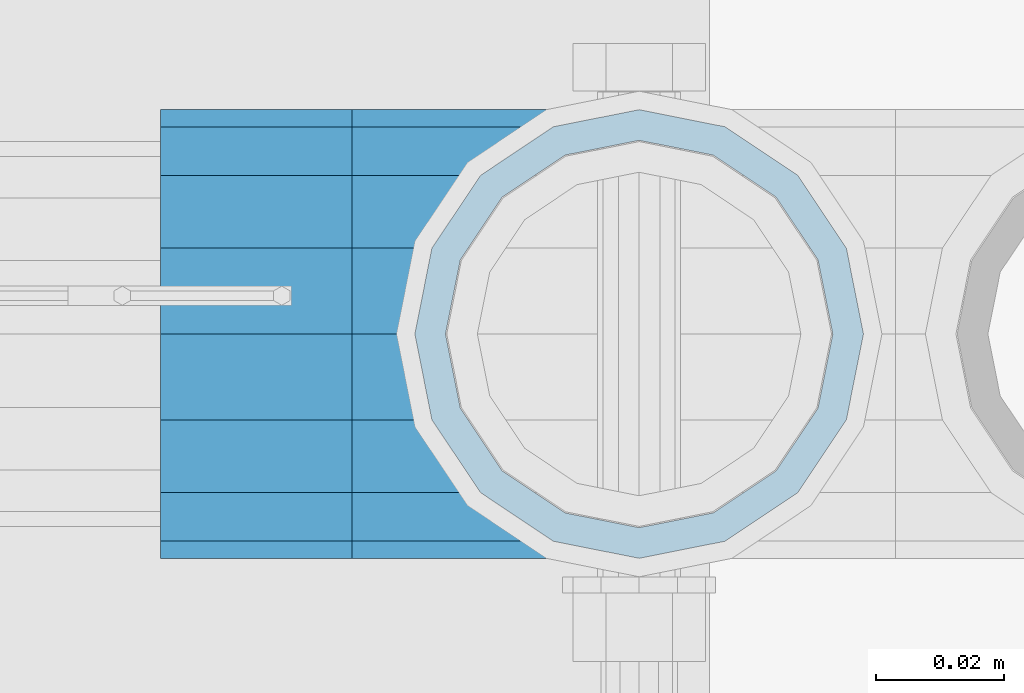
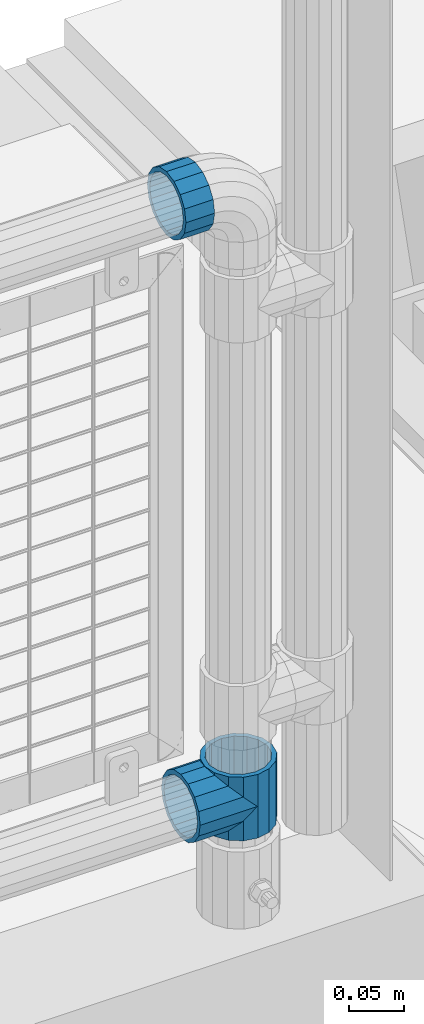
# One storey, part 169 of 242: 3 beams.
"""IFC2X3 building model written with IfcOpenShell, lengths in millimetres."""

from ifc_helpers import new_model, si_unit, frame, origin_with_axes, place, context, subcontext, project, spatial, faceted_brep, material, type_object, element, save


model = new_model("IFC2X3")

# Units and contexts
model_context = context("Model", 3, precision=1e-05, world=origin_with_axes())
body_context = subcontext(model_context, "Body", "Model", "MODEL_VIEW")
ifc_project = project(units=[si_unit("LENGTHUNIT", "METRE", prefix="MILLI"), si_unit("AREAUNIT", "SQUARE_METRE"), si_unit("VOLUMEUNIT", "CUBIC_METRE"), si_unit("MASSUNIT", "GRAM", prefix="KILO"), si_unit("TIMEUNIT", "SECOND"), si_unit("PLANEANGLEUNIT", "RADIAN"), si_unit("SOLIDANGLEUNIT", "STERADIAN"), si_unit("THERMODYNAMICTEMPERATUREUNIT", "DEGREE_CELSIUS"), si_unit("LUMINOUSINTENSITYUNIT", "LUMEN")], contexts=[model_context])

# Site, building, storey
site_placement = place(None, origin_with_axes())
site = spatial("IfcSite", under=ifc_project, at=site_placement, CompositionType="ELEMENT")
building_placement = place(site_placement, origin_with_axes())
building = spatial("IfcBuilding", under=site, at=building_placement, Name="Standard", CompositionType="ELEMENT")
storey_placement = place(building_placement, origin_with_axes())
storey = spatial("IfcBuildingStorey", under=building, at=storey_placement, Name="Undefined", CompositionType="ELEMENT", Elevation=0.0)

# Beams
ifc_material = material(Name="Misc_Undefined")
beam_type = type_object("IfcBeamType", PredefinedType="NOTDEFINED")
beam_1_placement = place(storey_placement, frame((-22656.0, -19335.5, 298.670000000001), z_axis=(0.0, 1.0, 0.0), x_axis=(-1.0, 0.0, 0.0)))
element("IfcBeam", 1, at=beam_1_placement, inside=storey, type_object=beam_type, material=ifc_material, context=body_context, shape_type="Brep", body=[
    faceted_brep([(0.0, 0.0, -35.1500000000015), (13.4513226476338, -13.4513226476329, -32.4743655677703), (13.4513226476338, 13.4513226476329, -32.4743655677703), (32.4743655677739, -26.8123795176754, 13.4513226476338), (32.4743655677739, -32.4743655677717, 13.4513226476338), (24.8548033587067, -24.8548033587072, 24.8548033587067), (24.8548033587067, -16.3810424080019, 24.8548033587067), (27.1226768591077, -21.4606908090117, 21.46069080901), (35.1500000000015, -30.35, 0.0), (35.1500000000015, -35.15, 0.0), (32.8397438117172, -28.0397438117175, 11.614442172282), (32.8397438117099, -28.0397438117175, -11.614442172282), (32.4743655677739, -26.8123795176754, -13.4513226476338), (32.4743655677739, -32.4743655677717, -13.4513226476338), (27.122676859115, -21.4606908090117, -21.46069080901), (24.8548033587067, -16.3810424080019, -24.8548033587067), (24.8548033587067, -24.8548033587072, -24.8548033587067), (20.0882031229849, -11.6144421722805, -28.0397438117179), (16.6306603983758, 0.0, -30.3499999999985), (20.0882031229849, 11.6144421722805, -28.0397438117179), (24.8548033587067, 16.3810424079986, -24.8548033587067), (24.8548033587067, 24.8548033587072, -24.8548033587067), (27.122676859115, 21.4606908090117, -21.46069080901), (32.4743655677739, 26.8123795176776, -13.4513226476338), (32.4743655677739, 32.4743655677717, -13.4513226476338), (32.8397438117099, 28.0397438117175, -11.614442172282), (35.1500000000015, 30.35, 0.0), (35.1500000000015, 35.1499999999996, 0.0), (32.8397438117172, 28.0397438117175, 11.614442172282), (32.4743655677739, 26.8123795176754, 13.4513226476338), (32.4743655677739, 32.4743655677717, 13.4513226476338), (27.1226768591077, 21.4606908090117, 21.46069080901), (24.8548033587067, 16.3810424080019, 24.8548033587067), (24.8548033587067, 24.8548033587072, 24.8548033587067), (13.4513226476338, 13.4513226476329, 32.4743655677703), (13.4513226476338, -13.4513226476329, 32.4743655677703), (0.0, 0.0, 35.1500000000015), (20.0882031229849, 11.6144421722805, 28.0397438117179), (16.6306603983685, 0.0, 30.3499999999985), (20.0882031229849, -11.6144421722805, 28.0397438117179), (60.1500000000015, -35.15, 0.0), (60.1500000000015, -32.4743655677717, 13.4513226476338), (60.1500000000015, -24.8548033587072, 24.8548033587067), (60.1500000000015, -13.4513226476329, 32.4743655677703), (60.1500000000015, 0.0, 35.1500000000015), (60.1500000000015, -24.8548033587072, -24.8548033587067), (60.1500000000015, -32.4743655677717, -13.4513226476338), (60.1500000000015, -13.4513226476329, -32.4743655677703), (60.1500000000015, 0.0, -35.1500000000015), (60.1500000000015, 13.4513226476329, -32.4743655677703), (60.1500000000015, 24.8548033587072, -24.8548033587067), (60.1500000000015, 32.4743655677717, -13.4513226476338), (60.1500000000015, 35.15, 0.0), (60.1500000000015, 32.4743655677717, 13.4513226476338), (60.1500000000015, 24.8548033587072, 24.8548033587067), (60.1500000000015, 13.4513226476329, 32.4743655677703), (60.1500000000015, -21.4606908090117, 21.46069080901), (60.1500000000015, -11.6144421722805, 28.0397438117179), (60.1500000000015, 0.0, 30.3499999999985), (60.1500000000015, 11.6144421722805, 28.0397438117179), (60.1500000000015, 21.4606908090117, 21.46069080901), (60.1500000000015, 28.0397438117175, 11.614442172282), (60.1500000000015, 30.35, 0.0), (60.1500000000015, 28.0397438117175, -11.614442172282), (60.1500000000015, 21.4606908090117, -21.46069080901), (60.1500000000015, 11.6144421722805, -28.0397438117179), (60.1500000000015, 0.0, -30.3499999999985), (60.1500000000015, -11.6144421722805, -28.0397438117179), (60.1500000000015, -21.4606908090117, -21.46069080901), (60.1500000000015, -28.0397438117175, -11.614442172282), (60.1500000000015, -30.35, 0.0), (60.1500000000015, -28.0397438117175, 11.614442172282)], [[[0, 1, 2]], [[3, 4, 5, 6, 7]], [[8, 9, 4, 3, 10]], [[11, 12, 13, 9, 8]], [[14, 15, 16, 13, 12]], [[2, 1, 16, 15, 17, 18, 19, 20, 21]], [[21, 20, 22, 23, 24]], [[24, 23, 25, 26, 27]], [[27, 26, 28, 29, 30]], [[30, 29, 31, 32, 33]], [[34, 35, 36]], [[33, 32, 37, 38, 39, 6, 5, 35, 34]], [[40, 41, 4, 9]], [[41, 42, 5, 4]], [[42, 43, 35, 5]], [[43, 44, 36, 35]], [[45, 46, 13, 16]], [[47, 45, 16, 1]], [[48, 47, 1, 0]], [[49, 48, 0, 2]], [[50, 49, 2, 21]], [[51, 50, 21, 24]], [[52, 51, 24, 27]], [[53, 52, 27, 30]], [[54, 53, 30, 33]], [[55, 54, 33, 34]], [[44, 55, 34, 36]], [[46, 40, 9, 13]], [[45, 47, 48, 49, 50, 51, 52, 53, 54, 55, 44, 43, 42, 41, 40, 46], [56, 57, 58, 59, 60, 61, 62, 63, 64, 65, 66, 67, 68, 69, 70, 71]], [[59, 58, 38, 37]], [[60, 59, 37, 32, 31]], [[61, 60, 31, 29, 28]], [[62, 61, 28, 26]], [[63, 62, 26, 25]], [[22, 64, 63, 25, 23]], [[19, 65, 64, 22, 20]], [[66, 65, 19, 18]], [[67, 66, 18, 17]], [[68, 67, 17, 15, 14]], [[69, 68, 14, 12, 11]], [[70, 69, 11, 8]], [[71, 70, 8, 10]], [[7, 56, 71, 10, 3]], [[39, 57, 56, 7, 6]], [[58, 57, 39, 38]]]),
])
beam_2_placement = place(storey_placement, frame((-22656.0, -19335.5, 333.820000000001), z_axis=(1.0, 0.0, 0.0), x_axis=(0.0, 0.0, -1.0)))
element("IfcBeam", 2, at=beam_2_placement, inside=storey, type_object=beam_type, material=ifc_material, context=body_context, shape_type="Brep", body=[
    faceted_brep([(56.6106908090114, 21.46069080901, -27.1226768591077), (56.6106908090114, 21.46069080901, -21.4606908090136), (46.7644421722801, 28.0397438117179, -11.6144421722784), (46.7644421722801, 28.0397438117179, -20.0882031229849), (51.5310424080006, 24.8548033587067, -24.8548033587067), (63.1897438117172, 11.614442172282, -32.8397438117245), (63.1897438117172, 11.614442172282, -28.0397438117143), (61.9623795176744, 13.4513226476338, -32.4743655677739), (65.4999999999997, 0.0, -35.1500000000015), (65.4999999999997, 0.0, -30.3499999999985), (63.1897438117172, -11.614442172282, -32.8397438117172), (63.1897438117172, -11.614442172282, -28.0397438117143), (61.9623795176767, -13.4513226476338, -32.4743655677739), (56.6106908090114, -21.46069080901, -27.1226768591077), (56.6106908090114, -21.46069080901, -21.4606908090136), (51.5310424079973, -24.8548033587067, -24.8548033587067), (46.7644421722801, -28.0397438117179, -20.0882031229921), (46.7644421722801, -28.0397438117179, -11.6144421722784), (35.1499999999996, -30.3499999999985, -16.6306603983758), (35.1500000000015, -30.35, 0.0), (23.5355578277191, -28.0397438117179, -20.0882031229921), (23.5355578277191, -28.0397438117179, -11.6144421722784), (13.6893091909879, -21.46069080901, -27.1226768591077), (13.6893091909879, -21.46069080901, -21.4606908090136), (18.7689575919975, -24.8548033587067, -24.8548033587067), (7.11025618828211, -11.614442172282, -32.8397438117172), (7.11025618828211, -11.614442172282, -28.0397438117143), (8.33762048232484, -13.4513226476338, -32.4743655677739), (4.79999999999961, 0.0, -35.1500000000015), (4.79999999999961, 0.0, -30.3499999999985), (7.11025618828211, 11.614442172282, -32.8397438117245), (7.11025618828211, 11.614442172282, -28.0397438117143), (8.33762048232262, 13.4513226476338, -32.4743655677739), (13.6893091909879, 21.46069080901, -27.1226768591077), (13.6893091909879, 21.46069080901, -21.4606908090136), (18.7689575919987, 24.8548033587067, -24.8548033587067), (23.5355578277192, 28.0397438117179, -20.0882031229849), (23.5355578277192, 28.0397438117179, -11.6144421722784), (35.1499999999996, 30.3499999999985, -16.6306603983685), (35.1500000000015, 30.35, 0.0), (0.0, 32.4743655677703, -13.4513226476338), (0.0, 35.1500000000015, 0.0), (70.2999999999993, 35.1500000000015, 0.0), (70.2999999999993, 32.4743655677703, -13.4513226476338), (0.0, 32.4743655677703, 13.4513226476338), (70.2999999999993, 32.4743655677703, 13.4513226476338), (0.0, 24.8548033587067, 24.8548033587067), (70.2999999999993, 24.8548033587067, 24.8548033587067), (0.0, 13.4513226476338, 32.4743655677739), (70.2999999999993, 13.4513226476338, 32.4743655677739), (0.0, 0.0, 35.1500000000015), (70.2999999999993, 0.0, 35.1500000000015), (0.0, -13.4513226476338, 32.4743655677739), (70.2999999999993, -13.4513226476338, 32.4743655677739), (0.0, -24.8548033587067, 24.8548033587067), (70.2999999999993, -24.8548033587067, 24.8548033587067), (0.0, -32.4743655677703, 13.4513226476338), (70.2999999999993, -32.4743655677703, 13.4513226476338), (0.0, -35.1500000000015, 0.0), (70.2999999999993, -35.1500000000015, 0.0), (70.2999999999993, -30.3499999999985, 0.0), (70.2999999999993, -28.0397438117179, -11.6144421722784), (70.2999999999993, -21.46069080901, -21.4606908090136), (70.2999999999993, -11.614442172282, -28.0397438117143), (70.2999999999993, 0.0, -30.3499999999985), (70.2999999999993, 11.614442172282, -28.0397438117143), (70.2999999999993, 21.46069080901, -21.4606908090136), (70.2999999999993, 28.0397438117179, -11.6144421722784), (0.0, -28.0397438117179, -11.6144421722784), (0.0, -30.3499999999985, 0.0), (0.0, -21.46069080901, -21.4606908090136), (0.0, -11.614442172282, -28.0397438117143), (0.0, 0.0, -30.3499999999985), (0.0, 11.614442172282, -28.0397438117143), (0.0, 21.46069080901, -21.4606908090136), (0.0, 28.0397438117179, -11.6144421722784), (0.0, 30.3499999999985, 0.0), (70.2999999999993, 30.3499999999985, 0.0), (0.0, 28.0397438117179, 11.6144421722784), (70.2999999999993, 28.0397438117179, 11.6144421722784), (0.0, 21.46069080901, 21.4606908090136), (70.2999999999993, 21.46069080901, 21.4606908090136), (0.0, 11.614442172282, 28.0397438117143), (70.2999999999993, 11.614442172282, 28.0397438117143), (0.0, 0.0, 30.3499999999985), (70.2999999999993, 0.0, 30.3499999999985), (0.0, -11.614442172282, 28.0397438117143), (70.2999999999993, -11.614442172282, 28.0397438117143), (0.0, -21.46069080901, 21.4606908090136), (70.2999999999993, -21.46069080901, 21.4606908090136), (0.0, -28.0397438117179, 11.6144421722784), (70.2999999999993, -28.0397438117179, 11.6144421722784), (70.2999999999993, -24.8548033587067, -24.8548033587067), (70.2999999999993, -13.4513226476338, -32.4743655677739), (70.2999999999993, 0.0, -35.1500000000015), (70.2999999999993, 13.4513226476338, -32.4743655677739), (70.2999999999993, 24.8548033587067, -24.8548033587067), (70.2999999999993, -32.4743655677703, -13.4513226476338), (0.0, -32.4743655677703, -13.4513226476338), (0.0, 24.8548033587067, -24.8548033587067), (0.0, 13.4513226476338, -32.4743655677739), (0.0, 0.0, -35.1500000000015), (0.0, -13.4513226476338, -32.4743655677739), (0.0, -24.8548033587067, -24.8548033587067)], [[[0, 1, 2, 3, 4]], [[5, 6, 1, 0, 7]], [[8, 9, 6, 5]], [[10, 11, 9, 8]], [[12, 13, 14, 11, 10]], [[15, 16, 17, 14, 13]], [[18, 19, 17, 16]], [[20, 21, 19, 18]], [[22, 23, 21, 20, 24]], [[25, 26, 23, 22, 27]], [[28, 29, 26, 25]], [[30, 31, 29, 28]], [[32, 33, 34, 31, 30]], [[35, 36, 37, 34, 33]], [[38, 39, 37, 36]], [[3, 2, 39, 38]], [[40, 41, 42, 43]], [[41, 44, 45, 42]], [[44, 46, 47, 45]], [[46, 48, 49, 47]], [[48, 50, 51, 49]], [[50, 52, 53, 51]], [[52, 54, 55, 53]], [[54, 56, 57, 55]], [[56, 58, 59, 57]], [[60, 61, 17, 19]], [[61, 62, 14, 17]], [[62, 63, 11, 14]], [[63, 64, 9, 11]], [[64, 65, 6, 9]], [[65, 66, 1, 6]], [[66, 67, 2, 1]], [[68, 69, 19, 21]], [[70, 68, 21, 23]], [[71, 70, 23, 26]], [[72, 71, 26, 29]], [[73, 72, 29, 31]], [[74, 73, 31, 34]], [[75, 74, 34, 37]], [[76, 75, 37, 39]], [[67, 77, 39, 2]], [[78, 76, 39, 77, 79]], [[80, 78, 79, 81]], [[82, 80, 81, 83]], [[84, 82, 83, 85]], [[86, 84, 85, 87]], [[88, 86, 87, 89]], [[90, 88, 89, 91]], [[19, 69, 90, 91, 60]], [[92, 93, 94, 95, 96, 43, 42, 45, 47, 49, 51, 53, 55, 57, 59, 97], [89, 87, 85, 83, 81, 79, 77, 67, 66, 65, 64, 63, 62, 61, 60, 91]], [[58, 98, 97, 59]], [[56, 54, 52, 50, 48, 46, 44, 41, 40, 99, 100, 101, 102, 103, 98, 58], [68, 70, 71, 72, 73, 74, 75, 76, 78, 80, 82, 84, 86, 88, 90, 69]], [[100, 99, 35, 33, 32]], [[101, 100, 32, 30, 28]], [[27, 102, 101, 28, 25]], [[24, 103, 102, 27, 22]], [[18, 16, 15, 92, 97, 98, 103, 24, 20]], [[93, 92, 15, 13, 12]], [[94, 93, 12, 10, 8]], [[7, 95, 94, 8, 5]], [[4, 96, 95, 7, 0]], [[99, 40, 43, 96, 4, 3, 38, 36, 35]]]),
])
beam_3_placement = place(storey_placement, frame((-22701.0, -19335.5, 969.85), z_axis=(0.0, 0.0, 1.0), x_axis=(-1.0, 0.0, 0.0)))
element("IfcBeam", 3, at=beam_3_placement, inside=storey, type_object=beam_type, material=ifc_material, context=body_context, shape_type="Brep", body=[
    faceted_brep([(0.0, -30.3499999999985, 0.0), (0.0, -28.0397438117179, 11.6144421722784), (30.0, -28.0397438117179, 11.6144421722805), (30.0, -30.3499999999985, 0.0), (0.0, -21.46069080901, 21.4606908090136), (30.0, -21.46069080901, 21.4606908090117), (0.0, -11.614442172282, 28.0397438117143), (30.0, -11.614442172282, 28.0397438117176), (0.0, 0.0, 30.3499999999985), (30.0, 0.0, 30.35), (0.0, 11.614442172282, 28.0397438117143), (30.0, 11.614442172282, 28.0397438117176), (0.0, 21.46069080901, 21.4606908090136), (30.0, 21.46069080901, 21.4606908090117), (0.0, 28.0397438117179, 11.6144421722784), (30.0, 28.0397438117179, 11.6144421722805), (0.0, 30.3499999999985, 0.0), (30.0, 30.3499999999985, 0.0), (0.0, 28.0397438117179, -11.6144421722784), (30.0, 28.0397438117179, -11.6144421722805), (0.0, 21.46069080901, -21.4606908090136), (30.0, 21.46069080901, -21.4606908090117), (0.0, 11.614442172282, -28.0397438117143), (30.0, 11.614442172282, -28.0397438117176), (0.0, 0.0, -30.3499999999985), (30.0, 0.0, -30.35), (0.0, -11.614442172282, -28.0397438117143), (30.0, -11.614442172282, -28.0397438117176), (0.0, -21.46069080901, -21.4606908090136), (30.0, -21.46069080901, -21.4606908090117), (0.0, -28.0397438117179, -11.6144421722784), (30.0, -28.0397438117179, -11.6144421722805), (0.0, -35.1500000000015, 0.0), (0.0, -32.4743655677703, -13.4513226476338), (30.0, -32.4743655677703, -13.4513226476329), (30.0, -35.1500000000015, 0.0), (0.0, -24.8548033587067, -24.8548033587067), (30.0, -24.8548033587067, -24.8548033587072), (0.0, -13.4513226476338, -32.4743655677739), (30.0, -13.4513226476338, -32.4743655677718), (0.0, 0.0, -35.1500000000015), (30.0, 0.0, -35.15), (0.0, 13.4513226476338, -32.4743655677739), (30.0, 13.4513226476338, -32.4743655677718), (0.0, 24.8548033587067, -24.8548033587067), (30.0, 24.8548033587067, -24.8548033587072), (0.0, 32.4743655677703, -13.4513226476338), (30.0, 32.4743655677703, -13.4513226476329), (0.0, 35.1500000000015, 0.0), (30.0, 35.1500000000015, 0.0), (0.0, 32.4743655677703, 13.4513226476338), (30.0, 32.4743655677703, 13.4513226476329), (0.0, 24.8548033587067, 24.8548033587067), (30.0, 24.8548033587067, 24.8548033587072), (0.0, 13.4513226476338, 32.4743655677739), (30.0, 13.4513226476338, 32.4743655677718), (0.0, 0.0, 35.1500000000015), (30.0, 0.0, 35.15), (0.0, -13.4513226476338, 32.4743655677739), (30.0, -13.4513226476338, 32.4743655677718), (0.0, -24.8548033587067, 24.8548033587067), (30.0, -24.8548033587067, 24.8548033587072), (0.0, -32.4743655677703, 13.4513226476338), (30.0, -32.4743655677703, 13.4513226476329)], [[[0, 1, 2, 3]], [[1, 4, 5, 2]], [[4, 6, 7, 5]], [[6, 8, 9, 7]], [[8, 10, 11, 9]], [[10, 12, 13, 11]], [[12, 14, 15, 13]], [[14, 16, 17, 15]], [[16, 18, 19, 17]], [[18, 20, 21, 19]], [[20, 22, 23, 21]], [[22, 24, 25, 23]], [[24, 26, 27, 25]], [[26, 28, 29, 27]], [[28, 30, 31, 29]], [[30, 0, 3, 31]], [[32, 33, 34, 35]], [[33, 36, 37, 34]], [[36, 38, 39, 37]], [[38, 40, 41, 39]], [[40, 42, 43, 41]], [[42, 44, 45, 43]], [[44, 46, 47, 45]], [[46, 48, 49, 47]], [[48, 50, 51, 49]], [[50, 52, 53, 51]], [[52, 54, 55, 53]], [[54, 56, 57, 55]], [[56, 58, 59, 57]], [[58, 60, 61, 59]], [[60, 62, 63, 61]], [[62, 32, 35, 63]], [[37, 39, 41, 43, 45, 47, 49, 51, 53, 55, 57, 59, 61, 63, 35, 34], [5, 7, 9, 11, 13, 15, 17, 19, 21, 23, 25, 27, 29, 31, 3, 2]], [[62, 60, 58, 56, 54, 52, 50, 48, 46, 44, 42, 40, 38, 36, 33, 32], [30, 28, 26, 24, 22, 20, 18, 16, 14, 12, 10, 8, 6, 4, 1, 0]]]),
])

save(model, "model.ifc")
